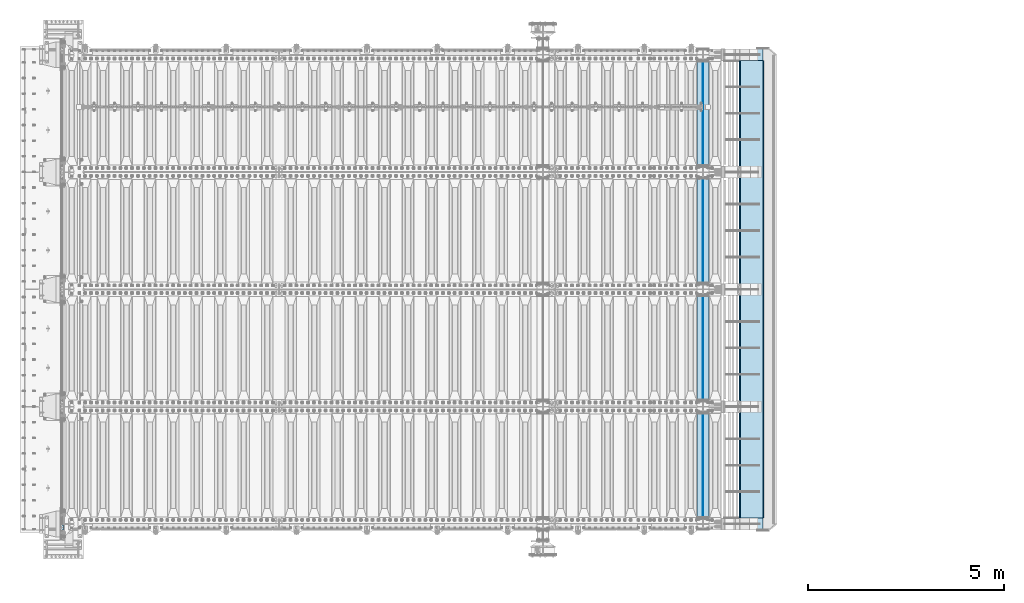
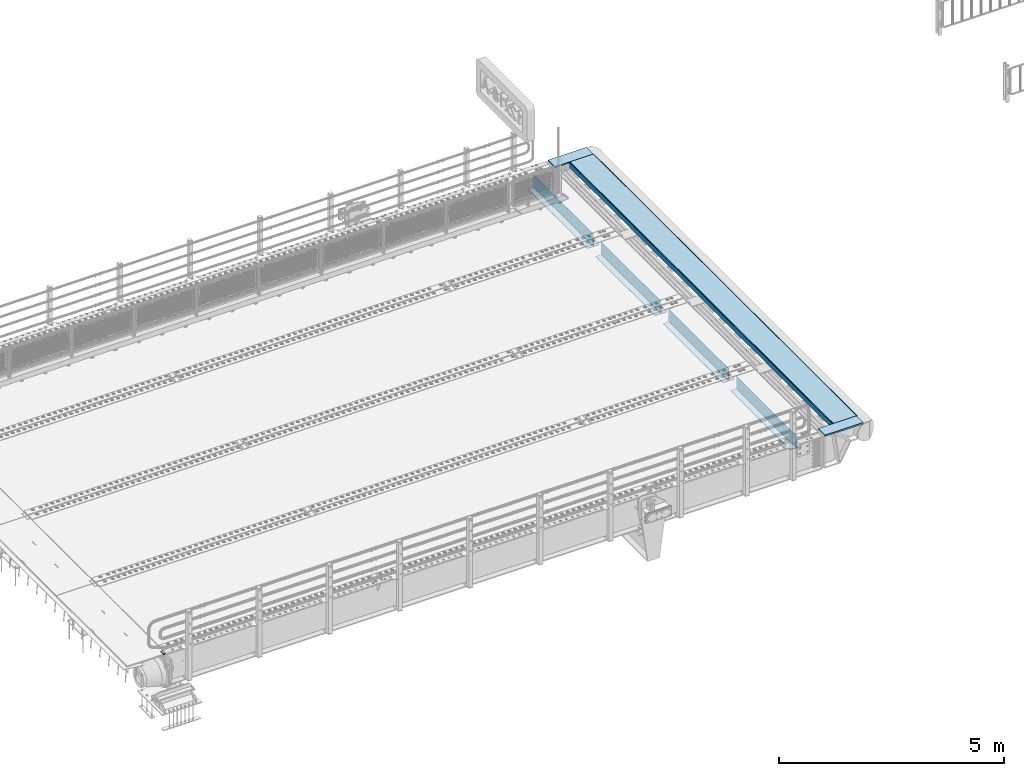
# One storey, part 201 of 257: 13 plates.
"""IFC2X3 building model written with IfcOpenShell, lengths in millimetres."""

from ifc_helpers import new_model, si_unit, frame, origin_with_axes, place, context, subcontext, project, spatial, faceted_brep, material, type_object, element, save


model = new_model("IFC2X3")

# Units and contexts
model_context = context("Model", 3, precision=1e-05, world=origin_with_axes())
body_context = subcontext(model_context, "Body", "Model", "MODEL_VIEW")
ifc_project = project(units=[si_unit("LENGTHUNIT", "METRE", prefix="MILLI"), si_unit("AREAUNIT", "SQUARE_METRE"), si_unit("VOLUMEUNIT", "CUBIC_METRE"), si_unit("MASSUNIT", "GRAM", prefix="KILO"), si_unit("TIMEUNIT", "SECOND"), si_unit("PLANEANGLEUNIT", "RADIAN"), si_unit("SOLIDANGLEUNIT", "STERADIAN"), si_unit("THERMODYNAMICTEMPERATUREUNIT", "DEGREE_CELSIUS"), si_unit("LUMINOUSINTENSITYUNIT", "LUMEN")], contexts=[model_context])

# Site, building, storey
site_placement = place(None, origin_with_axes())
site = spatial("IfcSite", under=ifc_project, at=site_placement, CompositionType="ELEMENT")
building_placement = place(site_placement, origin_with_axes())
building = spatial("IfcBuilding", under=site, at=building_placement, Name="Standard", CompositionType="ELEMENT")
storey_placement = place(building_placement, origin_with_axes())
storey = spatial("IfcBuildingStorey", under=building, at=storey_placement, Name="Undefined", CompositionType="ELEMENT", Elevation=0.0)

# Plates
ifc_material_1 = material()
plate_type_1 = type_object("IfcPlateType", PredefinedType="NOTDEFINED")
plate_1_placement = place(storey_placement, frame((42439.99999994, -89.9999995679937, -15.9997988356708), z_axis=(-1.0, 0.0, 0.0), x_axis=(0.0, -4.95099999998473e-06, 0.999999999987744)))
element("IfcPlate", 1, at=plate_1_placement, inside=storey, type_object=plate_type_1, material=ifc_material_1, context=body_context, shape_type="Brep", body=[
    faceted_brep([(0.0, -60.0, 0.0), (-0.000933120085687023, -60.0, 60.0), (-0.000933120085687023, 60.0, 59.9999999999927), (0.0, 60.0, -7.27595761418343e-12), (24.9991450303709, -60.0, 60.0), (24.9991450303709, 60.0, 59.9999999999927), (26.544215218168, -60.0, 59.7552873850873), (26.544215218168, 60.0, 59.75528738508), (27.9380461396139, -60.0, 59.0451032459096), (27.9380461396139, 60.0, 59.0451032459096), (29.0442025908961, -60.0, 57.9389639895744), (29.0442025908961, 60.0, 57.9389639895744), (29.7544083969366, -60.0, 56.5451441080368), (29.7544083969366, 60.0, 56.5451441080295), (29.9991450297669, -60.0, 55.0000777244568), (29.9991450297669, 60.0, 55.0000777244495), (29.999922274335, -60.0, 5.00007772445679), (29.999922274335, 60.0, 5.00007772444951), (29.7552240705896, -60.0, 3.45497416452417), (29.7552240705896, 60.0, 3.45497416452417), (29.0450346578116, -60.0, 2.06111146690819), (29.0450346578116, 60.0, 2.06111146690819), (27.9388736885072, -60.0, 0.954933302316931), (27.9388736885072, 60.0, 0.954933302316931), (26.5450220308766, -60.0, 0.244722222181736), (26.5450220308766, 60.0, 0.244722222181736), (24.9999222749392, -60.0, 0.0), (24.9999222749392, 60.0, -7.27595761418343e-12)], [[[0, 1, 2, 3]], [[1, 4, 5, 2]], [[4, 6, 7, 5]], [[6, 8, 9, 7]], [[8, 10, 11, 9]], [[10, 12, 13, 11]], [[12, 14, 15, 13]], [[14, 16, 17, 15]], [[16, 18, 19, 17]], [[18, 20, 21, 19]], [[20, 22, 23, 21]], [[22, 24, 25, 23]], [[24, 26, 27, 25]], [[26, 0, 3, 27]], [[5, 7, 9, 11, 13, 15, 17, 19, 21, 23, 25, 27, 3, 2]], [[26, 24, 22, 20, 18, 16, 14, 12, 10, 8, 6, 4, 1, 0]]]),
])
ifc_material_2 = material(Name="STEEL/S355N")
plate_type_2 = type_object("IfcPlateType", PredefinedType="NOTDEFINED")
for number, where, z_axis, x_axis in (
    (2, (58645.0, 175.0, -343.0), (0.0, 1.0, 0.0), (1.0, 0.0, 0.0)),
    (3, (58645.0, 6175.0, -343.0), (0.0, 1.0, 0.0), (1.0, 0.0, 0.0)),
    (4, (58645.0, 9175.0, -343.0), (0.0, 1.0, 0.0), (1.0, 0.0, 0.0)),
    (5, (58645.0, 3175.0, -343.0), (0.0, 1.0, 0.0), (1.0, 0.0, 0.0)),
):
    element("IfcPlate", number, at=place(storey_placement, frame(where, z_axis=z_axis, x_axis=x_axis)), inside=storey, type_object=plate_type_2, material=ifc_material_2, context=body_context, shape_type="Brep", body=[
        faceted_brep([(0.0, -7.0, 0.0), (0.0, -7.0, 2650.0), (0.0, 7.0, 2650.0), (0.0, 7.0, 0.0), (300.0, -7.0, 2650.0), (300.0, 7.0, 2650.0), (300.0, -7.0, 0.0), (300.0, 7.0, 0.0)], [[[0, 1, 2, 3]], [[1, 4, 5, 2]], [[4, 6, 7, 5]], [[6, 0, 3, 7]], [[5, 7, 3, 2]], [[6, 4, 1, 0]]]),
    ])
plate_type_3 = type_object("IfcPlateType", PredefinedType="NOTDEFINED")
for number, where, z_axis, x_axis in (
    (6, (58795.0, 2825.0, 0.0), (0.0, 0.0, -1.0), (0.0, -1.0, 0.0)),
    (7, (58795.0, 8825.0, 0.0), (0.0, 0.0, -1.0), (0.0, -1.0, 0.0)),
    (8, (58795.0, 11825.0, 0.0), (0.0, 0.0, -1.0), (0.0, -1.0, 0.0)),
    (9, (58795.0, 5825.0, 0.0), (0.0, 0.0, -1.0), (0.0, -1.0, 0.0)),
):
    element("IfcPlate", number, at=place(storey_placement, frame(where, z_axis=z_axis, x_axis=x_axis)), inside=storey, type_object=plate_type_3, material=ifc_material_2, context=body_context, shape_type="Brep", body=[
        faceted_brep([(0.0, -5.0, 0.0), (0.0, -5.0, 336.0), (0.0, 5.0, 336.0), (0.0, 5.0, 0.0), (2650.0, -5.0, 336.0), (2650.0, 5.0, 336.0), (2650.0, -5.0, 0.0), (2650.0, 5.0, 0.0)], [[[0, 1, 2, 3]], [[1, 4, 5, 2]], [[4, 6, 7, 5]], [[6, 0, 3, 7]], [[5, 7, 3, 2]], [[6, 4, 1, 0]]]),
    ])
plate_type_4 = type_object("IfcPlateType", PredefinedType="NOTDEFINED")
for number, where, z_axis, x_axis in (
    (10, (59346.9988298906, 150.0, -9.99999999985041), (1.0, 0.0, 0.0), (0.0, -1.0, 0.0)),
    (11, (59346.9988298905, 12150.0, -10.0000000004865), (1.0, 0.0, 0.0), (0.0, -1.0, 0.0)),
):
    element("IfcPlate", number, at=place(storey_placement, frame(where, z_axis=z_axis, x_axis=x_axis)), inside=storey, type_object=plate_type_4, material=ifc_material_2, context=body_context, shape_type="Brep", body=[
        faceted_brep([(300.0, 7.0, 986.0), (300.0, 20.0, 956.0), (-3.35091954184463e-11, 20.0, 956.0), (-3.45607986673713e-11, 7.0, 986.0), (0.0, 20.0, 0.0), (0.0, -20.0, 0.0), (-3.45607986673713e-11, -20.0, 986.0), (300.0, -20.0, 986.0), (300.0, -20.0, -1.81898940354586e-12), (300.0, 20.0, -1.81898940354586e-12)], [[[0, 1, 2, 3]], [[4, 5, 6, 3, 2]], [[6, 7, 0, 3]], [[7, 8, 9, 1, 0]], [[8, 5, 4, 9]], [[9, 4, 2, 1]], [[8, 7, 6, 5]]]),
    ])
plate_type_5 = type_object("IfcPlateType", PredefinedType="NOTDEFINED")
plate_2_placement = place(storey_placement, frame((59740.5545510642, 11850.0000000016, -155.274111776634), z_axis=(0.0, -1.0, 0.0), x_axis=(-0.0871556999854024, 0.0, 0.996194701832957)))
element("IfcPlate", 12, at=plate_2_placement, inside=storey, type_object=plate_type_5, material=ifc_material_2, context=body_context, shape_type="Brep", body=[
    faceted_brep([(0.0, -10.0, 0.0), (-9.09494701772928e-13, -10.0000000000073, 11700.0), (-9.09494701772928e-13, 10.0, 11700.0), (0.0, 10.0, 0.0), (154.999999999999, -10.0, 11700.0), (154.999999999998, 9.99999999999272, 11700.0), (154.999999999999, -10.0, 0.0), (154.999999999998, 9.99999999999272, 0.0)], [[[0, 1, 2, 3]], [[1, 4, 5, 2]], [[4, 6, 7, 5]], [[6, 0, 3, 7]], [[5, 7, 3, 2]], [[6, 4, 1, 0]]]),
])
plate_type_6 = type_object("IfcPlateType", PredefinedType="NOTDEFINED")
plate_3_placement = place(storey_placement, frame((59737.0029680259, 11850.0000000016, 0.00398537333359705), z_axis=(0.999999999980105, 3.15999999650637e-07, -6.29999999987466e-06), x_axis=(0.0, -1.0, 0.0)))
element("IfcPlate", 13, at=plate_3_placement, inside=storey, type_object=plate_type_6, material=ifc_material_2, context=body_context, shape_type="Brep", body=[
    faceted_brep([(11700.0, -10.0, 596.995666503914), (11700.0, -9.26425602898462e-13, 616.995666503906), (-3.17249941872433e-08, -9.2764684822555e-13, 616.995788574219), (-3.06972651742399e-08, -10.0, 596.995788574226), (-3.17249941872433e-08, 10.0, 616.995788574219), (0.0, 10.0, 0.0), (0.0, -10.0, 0.0), (11700.0, 10.0, 616.995666503906), (11700.0, -10.0, 1.07684172689915e-09), (11700.0, 10.0, 1.07684172689915e-09)], [[[0, 1, 2, 3]], [[4, 5, 6, 3, 2]], [[7, 4, 2, 1]], [[8, 9, 7, 1, 0]], [[8, 6, 5, 9]], [[7, 9, 5, 4]], [[6, 8, 0, 3]]]),
])

save(model, "model.ifc")
